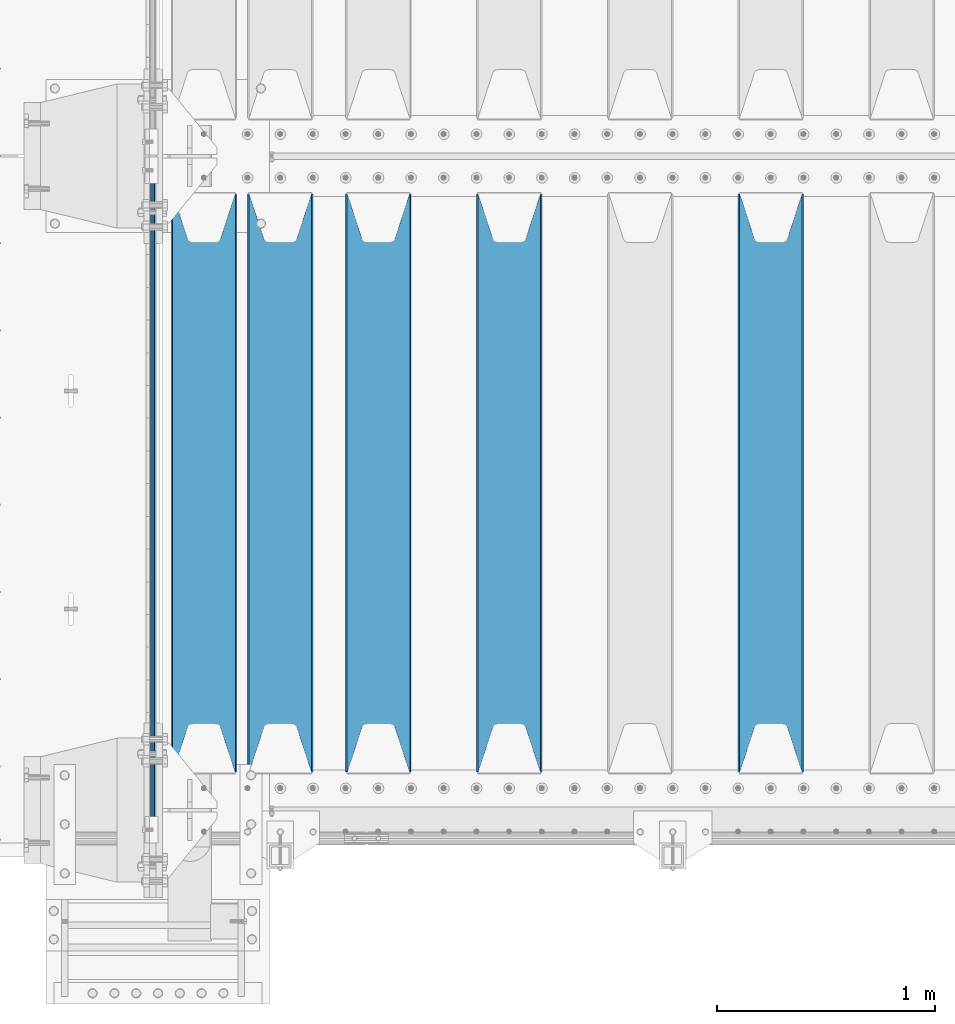
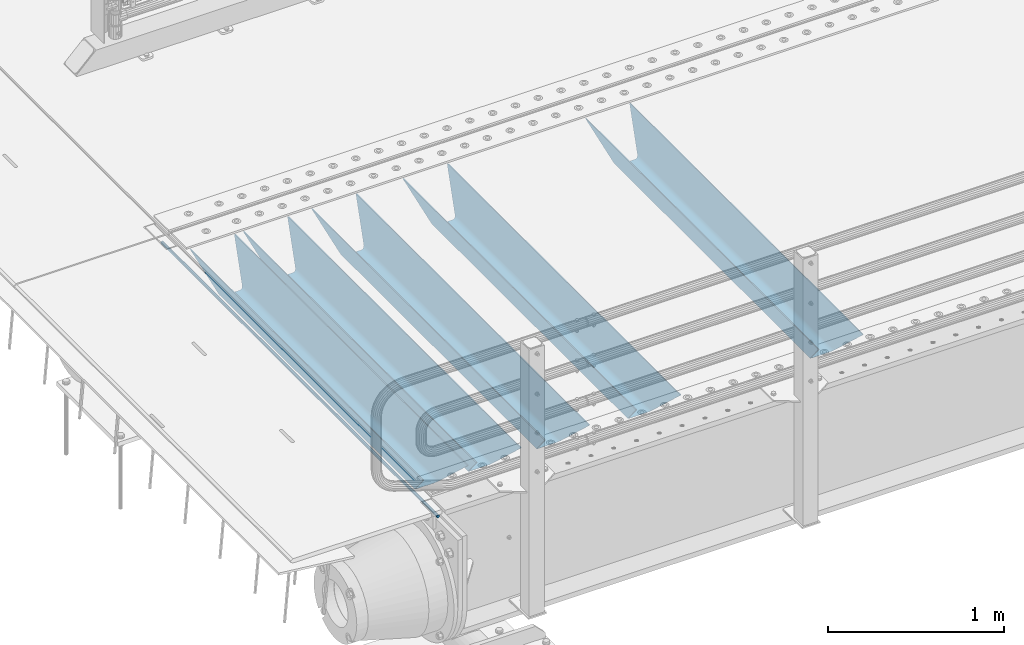
# One storey, part 110 of 242: 6 beams.
"""IFC2X3 building model written with IfcOpenShell, lengths in millimetres."""

from ifc_helpers import new_model, si_unit, frame, origin_with_axes, place, context, subcontext, project, spatial, faceted_brep, material, type_object, element, save


model = new_model("IFC2X3")

# Units and contexts
model_context = context("Model", 3, precision=1e-05, world=origin_with_axes())
body_context = subcontext(model_context, "Body", "Model", "MODEL_VIEW")
ifc_project = project(units=[si_unit("LENGTHUNIT", "METRE", prefix="MILLI"), si_unit("AREAUNIT", "SQUARE_METRE"), si_unit("VOLUMEUNIT", "CUBIC_METRE"), si_unit("MASSUNIT", "GRAM", prefix="KILO"), si_unit("TIMEUNIT", "SECOND"), si_unit("PLANEANGLEUNIT", "RADIAN"), si_unit("SOLIDANGLEUNIT", "STERADIAN"), si_unit("THERMODYNAMICTEMPERATUREUNIT", "DEGREE_CELSIUS"), si_unit("LUMINOUSINTENSITYUNIT", "LUMEN")], contexts=[model_context])

# Site, building, storey
site_placement = place(None, origin_with_axes())
site = spatial("IfcSite", under=ifc_project, at=site_placement, CompositionType="ELEMENT")
building_placement = place(site_placement, origin_with_axes())
building = spatial("IfcBuilding", under=site, at=building_placement, Name="Standard", CompositionType="ELEMENT")
storey_placement = place(building_placement, origin_with_axes())
storey = spatial("IfcBuildingStorey", under=building, at=storey_placement, Name="Undefined", CompositionType="ELEMENT", Elevation=0.0)

# Beams
ifc_material = material(Name="STEEL/S355N")
beam_type_1 = type_object("IfcBeamType", Name="D20", PredefinedType="NOTDEFINED")
beam_1_placement = place(storey_placement, frame((-42485.0, -24150.0, -26.0000191637567), z_axis=(0.0, 0.0, 1.0), x_axis=(0.0, 1.0, 0.0)))
element("IfcBeam", 1, at=beam_1_placement, inside=storey, type_object=beam_type_1, material=ifc_material, ObjectType="D20", context=body_context, shape_type="Brep", body=[
    faceted_brep([(0.0, -10.0, 0.0), (0.0, -7.07106781186303, -7.07106781186548), (3145.0, -7.07106781186303, -7.07106781186548), (3145.0, -10.0, 0.0), (0.0, 0.0, -10.0), (3145.0, 0.0, -10.0), (0.0, 7.07106781186303, -7.07106781186547), (3145.0, 7.07106781186303, -7.07106781186547), (0.0, 10.0, 0.0), (3145.0, 10.0, 0.0), (0.0, 7.07106781186303, 7.07106781186548), (3145.0, 7.07106781186303, 7.07106781186548), (0.0, 0.0, 10.0), (3145.0, 0.0, 10.0), (0.0, -7.07106781186303, 7.07106781186548), (3145.0, -7.07106781186303, 7.07106781186548)], [[[0, 1, 2, 3]], [[1, 4, 5, 2]], [[4, 6, 7, 5]], [[6, 8, 9, 7]], [[8, 10, 11, 9]], [[10, 12, 13, 11]], [[12, 14, 15, 13]], [[14, 0, 3, 15]], [[5, 7, 9, 11, 13, 15, 3, 2]], [[14, 12, 10, 8, 6, 4, 1, 0]]]),
])
beam_type_2 = type_object("IfcBeamType", PredefinedType="NOTDEFINED")
beam_2_placement = place(storey_placement, frame((-39650.0, -23825.0, -115.0), z_axis=(0.0, 0.0, 1.0), x_axis=(0.0, 1.0, 0.0)))
element("IfcBeam", 2, at=beam_2_placement, inside=storey, type_object=beam_type_2, material=ifc_material, context=body_context, shape_type="Brep", body=[
    faceted_brep([(0.0, 150.0, 115.0), (0.0, 143.689999999999, 115.0), (2650.00000000297, 143.689999999999, 115.0), (2650.00000000297, 150.0, 115.0), (2650.00000000297, 142.059565218402, 110.000000003099), (2650.00000000297, 148.369565218403, 110.000000003099), (2441.90079219209, -80.1103600731112, -98.0992078077845), (2437.7588105432, -77.5672621345584, -102.241189456673), (2434.06523489747, -74.4080125315522, -105.934765102404), (2430.91086095089, -70.710272125576, -109.089139048974), (2428.37322971128, -66.5649389910068, -111.626770288588), (2426.51472138055, -62.0739139532889, -113.485278619323), (2425.38102192092, -57.3475956567672, -114.618978078955), (2424.99999999987, -52.5021667386536, -115.0), (2424.99999999987, 52.5021667386536, -115.0), (2425.38102192092, 57.3475956567672, -114.618978078955), (2426.51472138055, 62.0739139532889, -113.485278619323), (2428.37322971128, 66.5649389910068, -111.626770288588), (2430.91086095089, 70.710272125576, -109.089139048974), (2434.06523489747, 74.4080125315522, -105.934765102404), (2437.7588105432, 77.5672621345584, -102.241189456673), (2441.90079219209, 80.1103600731112, -98.0992078077846), (2446.38936140511, 81.9747917625791, -93.6106385947584), (2448.2494850041, 76.2713538057251, -91.7505149957729), (2444.62967112262, 74.76777986261, -95.3703288772456), (2441.28936334126, 72.7168944282894, -98.710636658607), (2438.31067330438, 70.1691124903846, -101.689326695487), (2435.76682334747, 67.1870637758839, -104.233176652398), (2433.72034654133, 63.8440531834895, -106.279653458539), (2432.22154950042, 60.222258798236, -107.778450499454), (2431.30727574265, 56.4107117849089, -108.692724257221), (2430.99999999987, 52.5031078186876, -109.0), (2430.99999999987, -52.5031078186876, -109.0), (2431.30727574265, -56.4107117849089, -108.692724257221), (2432.22154950042, -60.222258798236, -107.778450499454), (2433.72034654133, -63.8440531834895, -106.279653458539), (2435.76682334747, -67.1870637758839, -104.233176652398), (2438.31067330438, -70.1691124903846, -101.689326695487), (2441.28936334126, -72.7168944282894, -98.7106366586071), (2444.62967112262, -74.76777986261, -95.3703288772457), (2448.2494850041, -76.2713538057251, -91.7505149957729), (2650.00000000297, -142.059565218402, 110.000000003099), (2650.00000000297, -148.369565218403, 110.000000003099), (2446.38936140511, -81.9747917625791, -93.6106385947584), (2650.00000000297, -143.689999999999, 115.0), (2650.00000000297, -150.0, 115.0), (0.0, -143.689999999999, 115.0), (0.0, -150.0, 115.0), (0.0, -148.369565218261, 110.000000002669), (203.610638597427, -81.9747917625791, -93.6106385947584), (208.099207810454, -80.1103600731112, -98.0992078077845), (212.241189459342, -77.5672621345584, -102.241189456673), (215.934765105074, -74.4080125315522, -105.934765102404), (219.089139051644, -70.710272125576, -109.089139048974), (221.626770291256, -66.5649389910068, -111.626770288588), (223.485278621993, -62.0739139532889, -113.485278619323), (224.618978081624, -57.3475956567672, -114.618978078955), (225.00000000267, -52.5021667386536, -115.0), (225.00000000267, 52.5021667386536, -115.0), (224.618978081624, 57.3475956567672, -114.618978078955), (223.485278621993, 62.0739139532889, -113.485278619323), (221.626770291256, 66.5649389910068, -111.626770288588), (219.089139051644, 70.710272125576, -109.089139048974), (215.934765105074, 74.4080125315522, -105.934765102404), (212.241189459342, 77.5672621345584, -102.241189456673), (208.099207810454, 80.1103600731112, -98.0992078077846), (203.610638597427, 81.9747917625791, -93.6106385947584), (0.0, 148.369565218261, 110.000000002669), (0.0, 142.05956521826, 110.000000002669), (201.750514998443, 76.2713538057251, -91.7505149957729), (205.370328879915, 74.76777986261, -95.3703288772456), (208.710636661275, 72.7168944282894, -98.710636658607), (211.689326698157, 70.1691124903846, -101.689326695487), (214.233176655067, 67.1870637758839, -104.233176652398), (216.279653461206, 63.8440531834895, -106.279653458539), (217.778450502123, 60.222258798236, -107.778450499454), (218.69272425989, 56.4107117849089, -108.692724257221), (219.00000000267, 52.5031078186876, -109.0), (219.00000000267, -52.5031078186876, -109.0), (218.69272425989, -56.4107117849089, -108.692724257221), (217.778450502123, -60.222258798236, -107.778450499454), (216.279653461206, -63.8440531834895, -106.279653458539), (214.233176655067, -67.1870637758839, -104.233176652398), (211.689326698157, -70.1691124903846, -101.689326695487), (208.710636661275, -72.7168944282894, -98.7106366586071), (205.370328879915, -74.76777986261, -95.3703288772457), (201.750514998443, -76.2713538057251, -91.7505149957729), (0.0, -142.05956521826, 110.000000002669)], [[[0, 1, 2, 3]], [[3, 2, 4, 5]], [[6, 7, 8, 9, 10, 11, 12, 13, 14, 15, 16, 17, 18, 19, 20, 21, 22, 5, 4, 23, 24, 25, 26, 27, 28, 29, 30, 31, 32, 33, 34, 35, 36, 37, 38, 39, 40, 41, 42, 43]], [[44, 45, 42, 41]], [[46, 47, 45, 44]], [[43, 42, 45, 47, 48, 49]], [[6, 43, 49, 50]], [[7, 6, 50, 51]], [[8, 7, 51, 52]], [[9, 8, 52, 53]], [[10, 9, 53, 54]], [[11, 10, 54, 55]], [[12, 11, 55, 56]], [[13, 12, 56, 57]], [[14, 13, 57, 58]], [[15, 14, 58, 59]], [[16, 15, 59, 60]], [[17, 16, 60, 61]], [[18, 17, 61, 62]], [[19, 18, 62, 63]], [[20, 19, 63, 64]], [[21, 20, 64, 65]], [[22, 21, 65, 66]], [[0, 3, 5, 22, 66, 67]], [[1, 0, 67, 68]], [[23, 4, 2, 1, 68, 69]], [[24, 23, 69, 70]], [[25, 24, 70, 71]], [[26, 25, 71, 72]], [[27, 26, 72, 73]], [[28, 27, 73, 74]], [[29, 28, 74, 75]], [[30, 29, 75, 76]], [[31, 30, 76, 77]], [[32, 31, 77, 78]], [[33, 32, 78, 79]], [[34, 33, 79, 80]], [[35, 34, 80, 81]], [[36, 35, 81, 82]], [[37, 36, 82, 83]], [[38, 37, 83, 84]], [[39, 38, 84, 85]], [[40, 39, 85, 86]], [[46, 44, 41, 40, 86, 87]], [[47, 46, 87, 48]], [[86, 85, 84, 83, 82, 81, 80, 79, 78, 77, 76, 75, 74, 73, 72, 71, 70, 69, 68, 67, 66, 65, 64, 63, 62, 61, 60, 59, 58, 57, 56, 55, 54, 53, 52, 51, 50, 49, 48, 87]]]),
])
beam_3_placement = place(storey_placement, frame((-40850.0, -23825.0, -115.0), z_axis=(0.0, 0.0, 1.0), x_axis=(0.0, 1.0, 0.0)))
element("IfcBeam", 3, at=beam_3_placement, inside=storey, type_object=beam_type_2, material=ifc_material, context=body_context, shape_type="Brep", body=[
    faceted_brep([(0.0, 150.0, 115.0), (0.0, 143.689999999999, 115.0), (2650.00000000297, 143.689999999999, 115.0), (2650.00000000297, 150.0, 115.0), (2650.00000000297, 142.059565218402, 110.000000003099), (2650.00000000297, 148.369565218403, 110.000000003099), (2441.90079219209, -80.1103600731112, -98.0992078077845), (2437.7588105432, -77.5672621345584, -102.241189456673), (2434.06523489747, -74.4080125315522, -105.934765102404), (2430.91086095089, -70.710272125576, -109.089139048974), (2428.37322971128, -66.5649389910068, -111.626770288588), (2426.51472138055, -62.0739139532889, -113.485278619323), (2425.38102192092, -57.3475956567672, -114.618978078955), (2424.99999999987, -52.5021667386536, -115.0), (2424.99999999987, 52.5021667386536, -115.0), (2425.38102192092, 57.3475956567672, -114.618978078955), (2426.51472138055, 62.0739139532889, -113.485278619323), (2428.37322971128, 66.5649389910068, -111.626770288588), (2430.91086095089, 70.710272125576, -109.089139048974), (2434.06523489747, 74.4080125315522, -105.934765102404), (2437.7588105432, 77.5672621345584, -102.241189456673), (2441.90079219209, 80.1103600731112, -98.0992078077846), (2446.38936140511, 81.9747917625791, -93.6106385947584), (2448.2494850041, 76.2713538057251, -91.7505149957729), (2444.62967112262, 74.76777986261, -95.3703288772456), (2441.28936334126, 72.7168944282894, -98.710636658607), (2438.31067330438, 70.1691124903846, -101.689326695487), (2435.76682334747, 67.1870637758839, -104.233176652398), (2433.72034654133, 63.8440531834895, -106.279653458539), (2432.22154950042, 60.222258798236, -107.778450499454), (2431.30727574265, 56.4107117849089, -108.692724257221), (2430.99999999987, 52.5031078186876, -109.0), (2430.99999999987, -52.5031078186876, -109.0), (2431.30727574265, -56.4107117849089, -108.692724257221), (2432.22154950042, -60.222258798236, -107.778450499454), (2433.72034654133, -63.8440531834895, -106.279653458539), (2435.76682334747, -67.1870637758839, -104.233176652398), (2438.31067330438, -70.1691124903846, -101.689326695487), (2441.28936334126, -72.7168944282894, -98.7106366586071), (2444.62967112262, -74.76777986261, -95.3703288772457), (2448.2494850041, -76.2713538057251, -91.7505149957729), (2650.00000000297, -142.059565218402, 110.000000003099), (2650.00000000297, -148.369565218403, 110.000000003099), (2446.38936140511, -81.9747917625791, -93.6106385947584), (2650.00000000297, -143.689999999999, 115.0), (2650.00000000297, -150.0, 115.0), (0.0, -143.689999999999, 115.0), (0.0, -150.0, 115.0), (0.0, -148.369565218261, 110.000000002669), (203.610638597427, -81.9747917625791, -93.6106385947584), (208.099207810454, -80.1103600731112, -98.0992078077845), (212.241189459342, -77.5672621345584, -102.241189456673), (215.934765105074, -74.4080125315522, -105.934765102404), (219.089139051644, -70.710272125576, -109.089139048974), (221.626770291256, -66.5649389910068, -111.626770288588), (223.485278621993, -62.0739139532889, -113.485278619323), (224.618978081624, -57.3475956567672, -114.618978078955), (225.00000000267, -52.5021667386536, -115.0), (225.00000000267, 52.5021667386536, -115.0), (224.618978081624, 57.3475956567672, -114.618978078955), (223.485278621993, 62.0739139532889, -113.485278619323), (221.626770291256, 66.5649389910068, -111.626770288588), (219.089139051644, 70.710272125576, -109.089139048974), (215.934765105074, 74.4080125315522, -105.934765102404), (212.241189459342, 77.5672621345584, -102.241189456673), (208.099207810454, 80.1103600731112, -98.0992078077846), (203.610638597427, 81.9747917625791, -93.6106385947584), (0.0, 148.369565218261, 110.000000002669), (0.0, 142.05956521826, 110.000000002669), (201.750514998443, 76.2713538057251, -91.7505149957729), (205.370328879915, 74.76777986261, -95.3703288772456), (208.710636661275, 72.7168944282894, -98.710636658607), (211.689326698157, 70.1691124903846, -101.689326695487), (214.233176655067, 67.1870637758839, -104.233176652398), (216.279653461206, 63.8440531834895, -106.279653458539), (217.778450502123, 60.222258798236, -107.778450499454), (218.69272425989, 56.4107117849089, -108.692724257221), (219.00000000267, 52.5031078186876, -109.0), (219.00000000267, -52.5031078186876, -109.0), (218.69272425989, -56.4107117849089, -108.692724257221), (217.778450502123, -60.222258798236, -107.778450499454), (216.279653461206, -63.8440531834895, -106.279653458539), (214.233176655067, -67.1870637758839, -104.233176652398), (211.689326698157, -70.1691124903846, -101.689326695487), (208.710636661275, -72.7168944282894, -98.7106366586071), (205.370328879915, -74.76777986261, -95.3703288772457), (201.750514998443, -76.2713538057251, -91.7505149957729), (0.0, -142.05956521826, 110.000000002669)], [[[0, 1, 2, 3]], [[3, 2, 4, 5]], [[6, 7, 8, 9, 10, 11, 12, 13, 14, 15, 16, 17, 18, 19, 20, 21, 22, 5, 4, 23, 24, 25, 26, 27, 28, 29, 30, 31, 32, 33, 34, 35, 36, 37, 38, 39, 40, 41, 42, 43]], [[44, 45, 42, 41]], [[46, 47, 45, 44]], [[43, 42, 45, 47, 48, 49]], [[6, 43, 49, 50]], [[7, 6, 50, 51]], [[8, 7, 51, 52]], [[9, 8, 52, 53]], [[10, 9, 53, 54]], [[11, 10, 54, 55]], [[12, 11, 55, 56]], [[13, 12, 56, 57]], [[14, 13, 57, 58]], [[15, 14, 58, 59]], [[16, 15, 59, 60]], [[17, 16, 60, 61]], [[18, 17, 61, 62]], [[19, 18, 62, 63]], [[20, 19, 63, 64]], [[21, 20, 64, 65]], [[22, 21, 65, 66]], [[0, 3, 5, 22, 66, 67]], [[1, 0, 67, 68]], [[23, 4, 2, 1, 68, 69]], [[24, 23, 69, 70]], [[25, 24, 70, 71]], [[26, 25, 71, 72]], [[27, 26, 72, 73]], [[28, 27, 73, 74]], [[29, 28, 74, 75]], [[30, 29, 75, 76]], [[31, 30, 76, 77]], [[32, 31, 77, 78]], [[33, 32, 78, 79]], [[34, 33, 79, 80]], [[35, 34, 80, 81]], [[36, 35, 81, 82]], [[37, 36, 82, 83]], [[38, 37, 83, 84]], [[39, 38, 84, 85]], [[40, 39, 85, 86]], [[46, 44, 41, 40, 86, 87]], [[47, 46, 87, 48]], [[86, 85, 84, 83, 82, 81, 80, 79, 78, 77, 76, 75, 74, 73, 72, 71, 70, 69, 68, 67, 66, 65, 64, 63, 62, 61, 60, 59, 58, 57, 56, 55, 54, 53, 52, 51, 50, 49, 48, 87]]]),
])
beam_4_placement = place(storey_placement, frame((-41450.0, -23825.0, -115.0), z_axis=(0.0, 0.0, 1.0), x_axis=(0.0, 1.0, 0.0)))
element("IfcBeam", 4, at=beam_4_placement, inside=storey, type_object=beam_type_2, material=ifc_material, context=body_context, shape_type="Brep", body=[
    faceted_brep([(0.0, 150.0, 115.0), (0.0, 143.689999999999, 115.0), (2650.00000000297, 143.689999999999, 115.0), (2650.00000000297, 150.0, 115.0), (2650.00000000297, 142.059565218402, 110.000000003099), (2650.00000000297, 148.369565218403, 110.000000003099), (2441.90079219209, -80.1103600731112, -98.0992078077845), (2437.7588105432, -77.5672621345584, -102.241189456673), (2434.06523489747, -74.4080125315522, -105.934765102404), (2430.91086095089, -70.710272125576, -109.089139048974), (2428.37322971128, -66.5649389910068, -111.626770288588), (2426.51472138055, -62.0739139532889, -113.485278619323), (2425.38102192092, -57.3475956567672, -114.618978078955), (2424.99999999987, -52.5021667386536, -115.0), (2424.99999999987, 52.5021667386536, -115.0), (2425.38102192092, 57.3475956567672, -114.618978078955), (2426.51472138055, 62.0739139532889, -113.485278619323), (2428.37322971128, 66.5649389910068, -111.626770288588), (2430.91086095089, 70.710272125576, -109.089139048974), (2434.06523489747, 74.4080125315522, -105.934765102404), (2437.7588105432, 77.5672621345584, -102.241189456673), (2441.90079219209, 80.1103600731112, -98.0992078077846), (2446.38936140511, 81.9747917625791, -93.6106385947584), (2448.2494850041, 76.2713538057251, -91.7505149957729), (2444.62967112262, 74.76777986261, -95.3703288772456), (2441.28936334126, 72.7168944282894, -98.710636658607), (2438.31067330438, 70.1691124903846, -101.689326695487), (2435.76682334747, 67.1870637758839, -104.233176652398), (2433.72034654133, 63.8440531834895, -106.279653458539), (2432.22154950042, 60.222258798236, -107.778450499454), (2431.30727574265, 56.4107117849089, -108.692724257221), (2430.99999999987, 52.5031078186876, -109.0), (2430.99999999987, -52.5031078186876, -109.0), (2431.30727574265, -56.4107117849089, -108.692724257221), (2432.22154950042, -60.222258798236, -107.778450499454), (2433.72034654133, -63.8440531834895, -106.279653458539), (2435.76682334747, -67.1870637758839, -104.233176652398), (2438.31067330438, -70.1691124903846, -101.689326695487), (2441.28936334126, -72.7168944282894, -98.7106366586071), (2444.62967112262, -74.76777986261, -95.3703288772457), (2448.2494850041, -76.2713538057251, -91.7505149957729), (2650.00000000297, -142.059565218402, 110.000000003099), (2650.00000000297, -148.369565218403, 110.000000003099), (2446.38936140511, -81.9747917625791, -93.6106385947584), (2650.00000000297, -143.689999999999, 115.0), (2650.00000000297, -150.0, 115.0), (0.0, -143.689999999999, 115.0), (0.0, -150.0, 115.0), (0.0, -148.369565218261, 110.000000002669), (203.610638597427, -81.9747917625791, -93.6106385947584), (208.099207810454, -80.1103600731112, -98.0992078077845), (212.241189459342, -77.5672621345584, -102.241189456673), (215.934765105074, -74.4080125315522, -105.934765102404), (219.089139051644, -70.710272125576, -109.089139048974), (221.626770291256, -66.5649389910068, -111.626770288588), (223.485278621993, -62.0739139532889, -113.485278619323), (224.618978081624, -57.3475956567672, -114.618978078955), (225.00000000267, -52.5021667386536, -115.0), (225.00000000267, 52.5021667386536, -115.0), (224.618978081624, 57.3475956567672, -114.618978078955), (223.485278621993, 62.0739139532889, -113.485278619323), (221.626770291256, 66.5649389910068, -111.626770288588), (219.089139051644, 70.710272125576, -109.089139048974), (215.934765105074, 74.4080125315522, -105.934765102404), (212.241189459342, 77.5672621345584, -102.241189456673), (208.099207810454, 80.1103600731112, -98.0992078077846), (203.610638597427, 81.9747917625791, -93.6106385947584), (0.0, 148.369565218261, 110.000000002669), (0.0, 142.05956521826, 110.000000002669), (201.750514998443, 76.2713538057251, -91.7505149957729), (205.370328879915, 74.76777986261, -95.3703288772456), (208.710636661275, 72.7168944282894, -98.710636658607), (211.689326698157, 70.1691124903846, -101.689326695487), (214.233176655067, 67.1870637758839, -104.233176652398), (216.279653461206, 63.8440531834895, -106.279653458539), (217.778450502123, 60.222258798236, -107.778450499454), (218.69272425989, 56.4107117849089, -108.692724257221), (219.00000000267, 52.5031078186876, -109.0), (219.00000000267, -52.5031078186876, -109.0), (218.69272425989, -56.4107117849089, -108.692724257221), (217.778450502123, -60.222258798236, -107.778450499454), (216.279653461206, -63.8440531834895, -106.279653458539), (214.233176655067, -67.1870637758839, -104.233176652398), (211.689326698157, -70.1691124903846, -101.689326695487), (208.710636661275, -72.7168944282894, -98.7106366586071), (205.370328879915, -74.76777986261, -95.3703288772457), (201.750514998443, -76.2713538057251, -91.7505149957729), (0.0, -142.05956521826, 110.000000002669)], [[[0, 1, 2, 3]], [[3, 2, 4, 5]], [[6, 7, 8, 9, 10, 11, 12, 13, 14, 15, 16, 17, 18, 19, 20, 21, 22, 5, 4, 23, 24, 25, 26, 27, 28, 29, 30, 31, 32, 33, 34, 35, 36, 37, 38, 39, 40, 41, 42, 43]], [[44, 45, 42, 41]], [[46, 47, 45, 44]], [[43, 42, 45, 47, 48, 49]], [[6, 43, 49, 50]], [[7, 6, 50, 51]], [[8, 7, 51, 52]], [[9, 8, 52, 53]], [[10, 9, 53, 54]], [[11, 10, 54, 55]], [[12, 11, 55, 56]], [[13, 12, 56, 57]], [[14, 13, 57, 58]], [[15, 14, 58, 59]], [[16, 15, 59, 60]], [[17, 16, 60, 61]], [[18, 17, 61, 62]], [[19, 18, 62, 63]], [[20, 19, 63, 64]], [[21, 20, 64, 65]], [[22, 21, 65, 66]], [[0, 3, 5, 22, 66, 67]], [[1, 0, 67, 68]], [[23, 4, 2, 1, 68, 69]], [[24, 23, 69, 70]], [[25, 24, 70, 71]], [[26, 25, 71, 72]], [[27, 26, 72, 73]], [[28, 27, 73, 74]], [[29, 28, 74, 75]], [[30, 29, 75, 76]], [[31, 30, 76, 77]], [[32, 31, 77, 78]], [[33, 32, 78, 79]], [[34, 33, 79, 80]], [[35, 34, 80, 81]], [[36, 35, 81, 82]], [[37, 36, 82, 83]], [[38, 37, 83, 84]], [[39, 38, 84, 85]], [[40, 39, 85, 86]], [[46, 44, 41, 40, 86, 87]], [[47, 46, 87, 48]], [[86, 85, 84, 83, 82, 81, 80, 79, 78, 77, 76, 75, 74, 73, 72, 71, 70, 69, 68, 67, 66, 65, 64, 63, 62, 61, 60, 59, 58, 57, 56, 55, 54, 53, 52, 51, 50, 49, 48, 87]]]),
])
beam_5_placement = place(storey_placement, frame((-41900.0, -23825.0, -115.0), z_axis=(0.0, 0.0, 1.0), x_axis=(0.0, 1.0, 0.0)))
element("IfcBeam", 5, at=beam_5_placement, inside=storey, type_object=beam_type_2, material=ifc_material, context=body_context, shape_type="Brep", body=[
    faceted_brep([(0.0, 150.0, 115.0), (0.0, 143.689999999999, 115.0), (2650.00000000297, 143.689999999999, 115.0), (2650.00000000297, 150.0, 115.0), (2650.00000000297, 142.059565218402, 110.000000003099), (2650.00000000297, 148.369565218403, 110.000000003099), (2441.90079219209, -80.1103600731112, -98.0992078077845), (2437.7588105432, -77.5672621345584, -102.241189456673), (2434.06523489747, -74.4080125315522, -105.934765102404), (2430.91086095089, -70.710272125576, -109.089139048974), (2428.37322971128, -66.5649389910068, -111.626770288588), (2426.51472138055, -62.0739139532889, -113.485278619323), (2425.38102192092, -57.3475956567672, -114.618978078955), (2424.99999999987, -52.5021667386536, -115.0), (2424.99999999987, 52.5021667386536, -115.0), (2425.38102192092, 57.3475956567672, -114.618978078955), (2426.51472138055, 62.0739139532889, -113.485278619323), (2428.37322971128, 66.5649389910068, -111.626770288588), (2430.91086095089, 70.710272125576, -109.089139048974), (2434.06523489747, 74.4080125315522, -105.934765102404), (2437.7588105432, 77.5672621345584, -102.241189456673), (2441.90079219209, 80.1103600731112, -98.0992078077846), (2446.38936140511, 81.9747917625791, -93.6106385947584), (2448.2494850041, 76.2713538057251, -91.7505149957729), (2444.62967112262, 74.76777986261, -95.3703288772456), (2441.28936334126, 72.7168944282894, -98.710636658607), (2438.31067330438, 70.1691124903846, -101.689326695487), (2435.76682334747, 67.1870637758839, -104.233176652398), (2433.72034654133, 63.8440531834895, -106.279653458539), (2432.22154950042, 60.222258798236, -107.778450499454), (2431.30727574265, 56.4107117849089, -108.692724257221), (2430.99999999987, 52.5031078186876, -109.0), (2430.99999999987, -52.5031078186876, -109.0), (2431.30727574265, -56.4107117849089, -108.692724257221), (2432.22154950042, -60.222258798236, -107.778450499454), (2433.72034654133, -63.8440531834895, -106.279653458539), (2435.76682334747, -67.1870637758839, -104.233176652398), (2438.31067330438, -70.1691124903846, -101.689326695487), (2441.28936334126, -72.7168944282894, -98.7106366586071), (2444.62967112262, -74.76777986261, -95.3703288772457), (2448.2494850041, -76.2713538057251, -91.7505149957729), (2650.00000000297, -142.059565218402, 110.000000003099), (2650.00000000297, -148.369565218403, 110.000000003099), (2446.38936140511, -81.9747917625791, -93.6106385947584), (2650.00000000297, -143.689999999999, 115.0), (2650.00000000297, -150.0, 115.0), (0.0, -143.689999999999, 115.0), (0.0, -150.0, 115.0), (0.0, -148.369565218261, 110.000000002669), (203.610638597427, -81.9747917625791, -93.6106385947584), (208.099207810454, -80.1103600731112, -98.0992078077845), (212.241189459342, -77.5672621345584, -102.241189456673), (215.934765105074, -74.4080125315522, -105.934765102404), (219.089139051644, -70.710272125576, -109.089139048974), (221.626770291256, -66.5649389910068, -111.626770288588), (223.485278621993, -62.0739139532889, -113.485278619323), (224.618978081624, -57.3475956567672, -114.618978078955), (225.00000000267, -52.5021667386536, -115.0), (225.00000000267, 52.5021667386536, -115.0), (224.618978081624, 57.3475956567672, -114.618978078955), (223.485278621993, 62.0739139532889, -113.485278619323), (221.626770291256, 66.5649389910068, -111.626770288588), (219.089139051644, 70.710272125576, -109.089139048974), (215.934765105074, 74.4080125315522, -105.934765102404), (212.241189459342, 77.5672621345584, -102.241189456673), (208.099207810454, 80.1103600731112, -98.0992078077846), (203.610638597427, 81.9747917625791, -93.6106385947584), (0.0, 148.369565218261, 110.000000002669), (0.0, 142.05956521826, 110.000000002669), (201.750514998443, 76.2713538057251, -91.7505149957729), (205.370328879915, 74.76777986261, -95.3703288772456), (208.710636661275, 72.7168944282894, -98.710636658607), (211.689326698157, 70.1691124903846, -101.689326695487), (214.233176655067, 67.1870637758839, -104.233176652398), (216.279653461206, 63.8440531834895, -106.279653458539), (217.778450502123, 60.222258798236, -107.778450499454), (218.69272425989, 56.4107117849089, -108.692724257221), (219.00000000267, 52.5031078186876, -109.0), (219.00000000267, -52.5031078186876, -109.0), (218.69272425989, -56.4107117849089, -108.692724257221), (217.778450502123, -60.222258798236, -107.778450499454), (216.279653461206, -63.8440531834895, -106.279653458539), (214.233176655067, -67.1870637758839, -104.233176652398), (211.689326698157, -70.1691124903846, -101.689326695487), (208.710636661275, -72.7168944282894, -98.7106366586071), (205.370328879915, -74.76777986261, -95.3703288772457), (201.750514998443, -76.2713538057251, -91.7505149957729), (0.0, -142.05956521826, 110.000000002669)], [[[0, 1, 2, 3]], [[3, 2, 4, 5]], [[6, 7, 8, 9, 10, 11, 12, 13, 14, 15, 16, 17, 18, 19, 20, 21, 22, 5, 4, 23, 24, 25, 26, 27, 28, 29, 30, 31, 32, 33, 34, 35, 36, 37, 38, 39, 40, 41, 42, 43]], [[44, 45, 42, 41]], [[46, 47, 45, 44]], [[43, 42, 45, 47, 48, 49]], [[6, 43, 49, 50]], [[7, 6, 50, 51]], [[8, 7, 51, 52]], [[9, 8, 52, 53]], [[10, 9, 53, 54]], [[11, 10, 54, 55]], [[12, 11, 55, 56]], [[13, 12, 56, 57]], [[14, 13, 57, 58]], [[15, 14, 58, 59]], [[16, 15, 59, 60]], [[17, 16, 60, 61]], [[18, 17, 61, 62]], [[19, 18, 62, 63]], [[20, 19, 63, 64]], [[21, 20, 64, 65]], [[22, 21, 65, 66]], [[0, 3, 5, 22, 66, 67]], [[1, 0, 67, 68]], [[23, 4, 2, 1, 68, 69]], [[24, 23, 69, 70]], [[25, 24, 70, 71]], [[26, 25, 71, 72]], [[27, 26, 72, 73]], [[28, 27, 73, 74]], [[29, 28, 74, 75]], [[30, 29, 75, 76]], [[31, 30, 76, 77]], [[32, 31, 77, 78]], [[33, 32, 78, 79]], [[34, 33, 79, 80]], [[35, 34, 80, 81]], [[36, 35, 81, 82]], [[37, 36, 82, 83]], [[38, 37, 83, 84]], [[39, 38, 84, 85]], [[40, 39, 85, 86]], [[46, 44, 41, 40, 86, 87]], [[47, 46, 87, 48]], [[86, 85, 84, 83, 82, 81, 80, 79, 78, 77, 76, 75, 74, 73, 72, 71, 70, 69, 68, 67, 66, 65, 64, 63, 62, 61, 60, 59, 58, 57, 56, 55, 54, 53, 52, 51, 50, 49, 48, 87]]]),
])
beam_6_placement = place(storey_placement, frame((-42250.0, -23825.0, -115.0), z_axis=(0.0, 0.0, 1.0), x_axis=(0.0, 1.0, 0.0)))
element("IfcBeam", 6, at=beam_6_placement, inside=storey, type_object=beam_type_2, material=ifc_material, context=body_context, shape_type="Brep", body=[
    faceted_brep([(0.0, 150.0, 115.0), (0.0, 143.689999999999, 115.0), (2650.00000000297, 143.689999999999, 115.0), (2650.00000000297, 150.0, 115.0), (2650.00000000297, 142.059565218402, 110.000000003099), (2650.00000000297, 148.369565218403, 110.000000003099), (2441.90079219209, -80.1103600731112, -98.0992078077845), (2437.7588105432, -77.5672621345584, -102.241189456673), (2434.06523489747, -74.4080125315522, -105.934765102404), (2430.91086095089, -70.710272125576, -109.089139048974), (2428.37322971128, -66.5649389910068, -111.626770288588), (2426.51472138055, -62.0739139532889, -113.485278619323), (2425.38102192092, -57.3475956567672, -114.618978078955), (2424.99999999987, -52.5021667386536, -115.0), (2424.99999999987, 52.5021667386536, -115.0), (2425.38102192092, 57.3475956567672, -114.618978078955), (2426.51472138055, 62.0739139532889, -113.485278619323), (2428.37322971128, 66.5649389910068, -111.626770288588), (2430.91086095089, 70.710272125576, -109.089139048974), (2434.06523489747, 74.4080125315522, -105.934765102404), (2437.7588105432, 77.5672621345584, -102.241189456673), (2441.90079219209, 80.1103600731112, -98.0992078077846), (2446.38936140511, 81.9747917625791, -93.6106385947584), (2448.2494850041, 76.2713538057251, -91.7505149957729), (2444.62967112262, 74.76777986261, -95.3703288772456), (2441.28936334126, 72.7168944282894, -98.710636658607), (2438.31067330438, 70.1691124903846, -101.689326695487), (2435.76682334747, 67.1870637758839, -104.233176652398), (2433.72034654133, 63.8440531834895, -106.279653458539), (2432.22154950042, 60.222258798236, -107.778450499454), (2431.30727574265, 56.4107117849089, -108.692724257221), (2430.99999999987, 52.5031078186876, -109.0), (2430.99999999987, -52.5031078186876, -109.0), (2431.30727574265, -56.4107117849089, -108.692724257221), (2432.22154950042, -60.222258798236, -107.778450499454), (2433.72034654133, -63.8440531834895, -106.279653458539), (2435.76682334747, -67.1870637758839, -104.233176652398), (2438.31067330438, -70.1691124903846, -101.689326695487), (2441.28936334126, -72.7168944282894, -98.7106366586071), (2444.62967112262, -74.76777986261, -95.3703288772457), (2448.2494850041, -76.2713538057251, -91.7505149957729), (2650.00000000297, -142.059565218402, 110.000000003099), (2650.00000000297, -148.369565218403, 110.000000003099), (2446.38936140511, -81.9747917625791, -93.6106385947584), (2650.00000000297, -143.689999999999, 115.0), (2650.00000000297, -150.0, 115.0), (0.0, -143.689999999999, 115.0), (0.0, -150.0, 115.0), (0.0, -148.369565218261, 110.000000002669), (203.610638597427, -81.9747917625791, -93.6106385947584), (208.099207810454, -80.1103600731112, -98.0992078077845), (212.241189459342, -77.5672621345584, -102.241189456673), (215.934765105074, -74.4080125315522, -105.934765102404), (219.089139051644, -70.710272125576, -109.089139048974), (221.626770291256, -66.5649389910068, -111.626770288588), (223.485278621993, -62.0739139532889, -113.485278619323), (224.618978081624, -57.3475956567672, -114.618978078955), (225.00000000267, -52.5021667386536, -115.0), (225.00000000267, 52.5021667386536, -115.0), (224.618978081624, 57.3475956567672, -114.618978078955), (223.485278621993, 62.0739139532889, -113.485278619323), (221.626770291256, 66.5649389910068, -111.626770288588), (219.089139051644, 70.710272125576, -109.089139048974), (215.934765105074, 74.4080125315522, -105.934765102404), (212.241189459342, 77.5672621345584, -102.241189456673), (208.099207810454, 80.1103600731112, -98.0992078077846), (203.610638597427, 81.9747917625791, -93.6106385947584), (0.0, 148.369565218261, 110.000000002669), (0.0, 142.05956521826, 110.000000002669), (201.750514998443, 76.2713538057251, -91.7505149957729), (205.370328879915, 74.76777986261, -95.3703288772456), (208.710636661275, 72.7168944282894, -98.710636658607), (211.689326698157, 70.1691124903846, -101.689326695487), (214.233176655067, 67.1870637758839, -104.233176652398), (216.279653461206, 63.8440531834895, -106.279653458539), (217.778450502123, 60.222258798236, -107.778450499454), (218.69272425989, 56.4107117849089, -108.692724257221), (219.00000000267, 52.5031078186876, -109.0), (219.00000000267, -52.5031078186876, -109.0), (218.69272425989, -56.4107117849089, -108.692724257221), (217.778450502123, -60.222258798236, -107.778450499454), (216.279653461206, -63.8440531834895, -106.279653458539), (214.233176655067, -67.1870637758839, -104.233176652398), (211.689326698157, -70.1691124903846, -101.689326695487), (208.710636661275, -72.7168944282894, -98.7106366586071), (205.370328879915, -74.76777986261, -95.3703288772457), (201.750514998443, -76.2713538057251, -91.7505149957729), (0.0, -142.05956521826, 110.000000002669)], [[[0, 1, 2, 3]], [[3, 2, 4, 5]], [[6, 7, 8, 9, 10, 11, 12, 13, 14, 15, 16, 17, 18, 19, 20, 21, 22, 5, 4, 23, 24, 25, 26, 27, 28, 29, 30, 31, 32, 33, 34, 35, 36, 37, 38, 39, 40, 41, 42, 43]], [[44, 45, 42, 41]], [[46, 47, 45, 44]], [[43, 42, 45, 47, 48, 49]], [[6, 43, 49, 50]], [[7, 6, 50, 51]], [[8, 7, 51, 52]], [[9, 8, 52, 53]], [[10, 9, 53, 54]], [[11, 10, 54, 55]], [[12, 11, 55, 56]], [[13, 12, 56, 57]], [[14, 13, 57, 58]], [[15, 14, 58, 59]], [[16, 15, 59, 60]], [[17, 16, 60, 61]], [[18, 17, 61, 62]], [[19, 18, 62, 63]], [[20, 19, 63, 64]], [[21, 20, 64, 65]], [[22, 21, 65, 66]], [[0, 3, 5, 22, 66, 67]], [[1, 0, 67, 68]], [[23, 4, 2, 1, 68, 69]], [[24, 23, 69, 70]], [[25, 24, 70, 71]], [[26, 25, 71, 72]], [[27, 26, 72, 73]], [[28, 27, 73, 74]], [[29, 28, 74, 75]], [[30, 29, 75, 76]], [[31, 30, 76, 77]], [[32, 31, 77, 78]], [[33, 32, 78, 79]], [[34, 33, 79, 80]], [[35, 34, 80, 81]], [[36, 35, 81, 82]], [[37, 36, 82, 83]], [[38, 37, 83, 84]], [[39, 38, 84, 85]], [[40, 39, 85, 86]], [[46, 44, 41, 40, 86, 87]], [[47, 46, 87, 48]], [[86, 85, 84, 83, 82, 81, 80, 79, 78, 77, 76, 75, 74, 73, 72, 71, 70, 69, 68, 67, 66, 65, 64, 63, 62, 61, 60, 59, 58, 57, 56, 55, 54, 53, 52, 51, 50, 49, 48, 87]]]),
])

save(model, "model.ifc")
